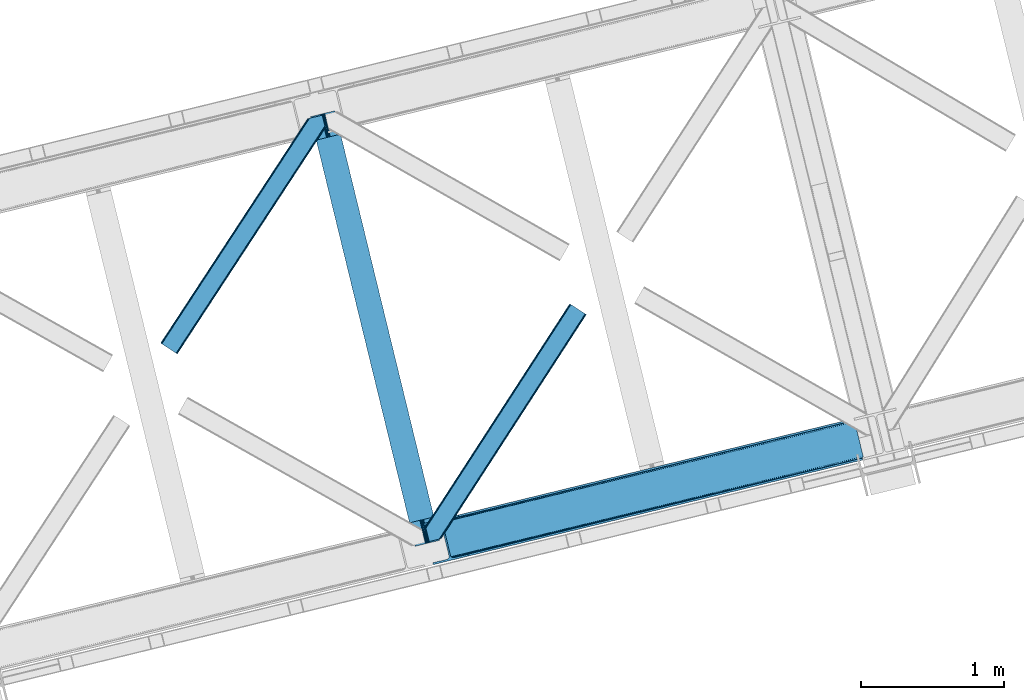
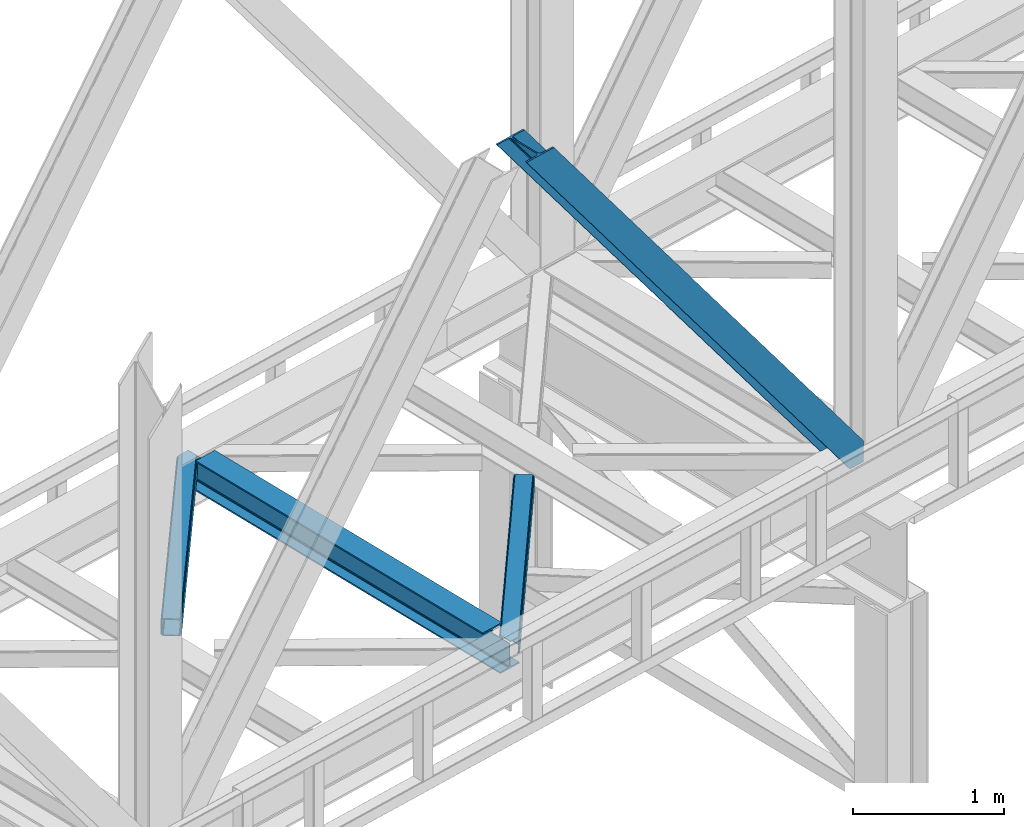
# One storey, part 53 of 93: 3 members, 1 beam.
"""IFC4 building model written with IfcOpenShell, lengths in millimetres."""

from ifc_helpers import new_model, entity, si_unit, converted_unit, derived_unit, direction, frame, origin, place, context, subcontext, project, spatial, triangles, polygons, material, type_object, element, save


model = new_model("IFC4")

# Units and contexts
model_context = context("Model", 3, precision=0.01, world=origin(), true_north=direction((6.12303176911189e-17, 1.0)))
plan_context = context("Plan", 3, precision=0.01, world=origin(), true_north=direction((6.12303176911189e-17, 1.0)))
body_context = subcontext(model_context, "Body", "Model", "MODEL_VIEW")
ifc_project = project(units=[si_unit("LENGTHUNIT", "METRE", prefix="MILLI"), si_unit("AREAUNIT", "SQUARE_METRE"), si_unit("VOLUMEUNIT", "CUBIC_METRE"), converted_unit("PLANEANGLEUNIT", "DEGREE", entity("IfcRatioMeasure", 0.0174532925199433), si_unit("PLANEANGLEUNIT", "RADIAN"), dimensions=[0, 0, 0, 0, 0, 0, 0]), si_unit("MASSUNIT", "GRAM", prefix="KILO"), derived_unit("MASSDENSITYUNIT", [(si_unit("MASSUNIT", "GRAM", prefix="KILO"), 1), (si_unit("LENGTHUNIT", "METRE"), -3)]), derived_unit("MOMENTOFINERTIAUNIT", [(si_unit("LENGTHUNIT", "METRE"), 4)]), si_unit("TIMEUNIT", "SECOND"), si_unit("FREQUENCYUNIT", "HERTZ"), si_unit("THERMODYNAMICTEMPERATUREUNIT", "DEGREE_CELSIUS"), derived_unit("THERMALTRANSMITTANCEUNIT", [(si_unit("MASSUNIT", "GRAM", prefix="KILO"), 1), (si_unit("THERMODYNAMICTEMPERATUREUNIT", "KELVIN"), -1), (si_unit("TIMEUNIT", "SECOND"), -3)]), derived_unit("VOLUMETRICFLOWRATEUNIT", [(si_unit("LENGTHUNIT", "METRE"), 3), (si_unit("TIMEUNIT", "SECOND"), -1)]), derived_unit("MASSFLOWRATEUNIT", [(si_unit("MASSUNIT", "GRAM", prefix="KILO"), 1), (si_unit("TIMEUNIT", "SECOND"), -1)]), derived_unit("ROTATIONALFREQUENCYUNIT", [(si_unit("TIMEUNIT", "SECOND"), -1)]), si_unit("ELECTRICCURRENTUNIT", "AMPERE"), si_unit("ELECTRICVOLTAGEUNIT", "VOLT"), si_unit("POWERUNIT", "WATT"), si_unit("FORCEUNIT", "NEWTON", prefix="KILO"), si_unit("ILLUMINANCEUNIT", "LUX"), si_unit("LUMINOUSFLUXUNIT", "LUMEN"), si_unit("LUMINOUSINTENSITYUNIT", "CANDELA"), derived_unit("USERDEFINED", [(si_unit("MASSUNIT", "GRAM", prefix="KILO"), -1), (si_unit("LENGTHUNIT", "METRE"), -2), (si_unit("TIMEUNIT", "SECOND"), 3), (si_unit("LUMINOUSFLUXUNIT", "LUMEN"), 1)]), derived_unit("LINEARVELOCITYUNIT", [(si_unit("LENGTHUNIT", "METRE"), 1), (si_unit("TIMEUNIT", "SECOND"), -1)]), si_unit("PRESSUREUNIT", "PASCAL"), derived_unit("USERDEFINED", [(si_unit("LENGTHUNIT", "METRE"), -2), (si_unit("MASSUNIT", "GRAM", prefix="KILO"), 1), (si_unit("TIMEUNIT", "SECOND"), -2)]), derived_unit("LINEARFORCEUNIT", [(si_unit("MASSUNIT", "GRAM", prefix="KILO"), 1), (si_unit("LENGTHUNIT", "METRE"), 1), (si_unit("TIMEUNIT", "SECOND"), -2), (si_unit("LENGTHUNIT", "METRE"), -1)]), derived_unit("PLANARFORCEUNIT", [(si_unit("MASSUNIT", "GRAM", prefix="KILO"), 1), (si_unit("LENGTHUNIT", "METRE"), 1), (si_unit("TIMEUNIT", "SECOND"), -2), (si_unit("LENGTHUNIT", "METRE"), -2)])], contexts=[model_context, plan_context])

# Site, building, storey
site_placement = place(None, origin())
site = spatial("IfcSite", under=ifc_project, at=site_placement, CompositionType="ELEMENT")
building_placement = place(site_placement, origin())
building = spatial("IfcBuilding", under=site, at=building_placement, CompositionType="ELEMENT")
storey_placement = place(building_placement, frame((0.0, 0.0, 15900.0)))
storey = spatial("IfcBuildingStorey", under=building, at=storey_placement, CompositionType="ELEMENT", Elevation=15900.0)

# Beam
ifc_material = material(Name="Metal painted (White)")
beam_type = type_object("IfcBeamType", PredefinedType="BEAM")
beam_placement = place(storey_placement, frame((-33403.9832699759, 9644.13047468046, 3441.0)))
element("IfcBeam", 1, at=beam_placement, inside=storey, type_object=beam_type, material=ifc_material, ObjectType="Steel Beam", PredefinedType="BEAM", context=body_context, shape_type="Tessellation", body=[
    polygons([(900.98534618944, 41.4445662733092, 11.000000000004), (900.98534618944, 41.4445662733092, 2.16573425859679e-12), (170.021610174761, 3040.13999372697, 2.16573425859679e-12), (170.021610174761, 3040.13999372697, 11.000000000004), (834.919806235814, 25.3403919499667, 11.000000000004), (103.956070221144, 3024.03581940363, 11.000000000004), (828.971056214522, 23.8903211957407, 12.2179274798217), (98.0073201998513, 3022.5857486494, 12.2179274798217), (823.927949458409, 22.6610105689183, 15.6862915010235), (92.964213443734, 3021.35643802258, 15.6862915010235), (820.558253255237, 21.8396114687119, 20.8770650821657), (89.5945172405668, 3020.53503892237, 20.8770650821657), (819.374973305552, 21.5511744621206, 27.0000000000047), (88.4112372908723, 3020.24660191578, 27.0000000000047), (81.6103728838844, 3018.58881926485, 27.0000000000025), (81.6103728838801, 3018.58881926485, 203.000000000006), (88.4112372908723, 3020.24660191578, 203.000000000006), (0.0, 2998.69542745366, 2.16573425859679e-12), (0.0, 2998.69542745366, 10.9999999999997), (66.0655399536216, 3014.799601777, 11.000000000004), (72.014289974914, 3016.24967253123, 12.2179274798217), (77.0573967310226, 3017.47898315805, 15.6862915010192), (80.4270929342029, 3018.30038225826, 20.8770650821657), (819.374973305552, 21.5511744621206, 203.000000000006), (812.574108898559, 19.8933918111876, 203.000000000006), (812.574108898559, 19.8933918111876, 27.0000000000025), (811.390828948882, 19.6049548045984, 20.8770650821657), (808.021132745702, 18.7835557043887, 15.6862915010192), (802.978025989593, 17.5542450775685, 12.2179274798217), (797.029275968301, 16.1041743233436, 11.000000000004), (730.963736014679, 0.0, 10.9999999999997), (730.963736014679, 0.0, 2.16573425859679e-12), (779.675212882766, 184.415062601693, 203.069791966819), (128.020401343512, 2857.75452019162, 203.000000000006), (128.243282132663, 2856.8401777572, 203.617301946336), (128.256196377186, 2856.7871977843, 217.000003693143), (779.530009633837, 185.010597404073, 217.000003676718), (779.530880241731, 185.007025963196, 204.00000679514), (772.96491171832, 182.385463974442, 203.006342981529), (772.742064056782, 183.299815969777, 203.617301946336), (772.729149812254, 183.352795942668, 217.000003693143), (121.455336555608, 2855.1293963229, 217.000003676718), (121.454465947714, 2855.13296776377, 204.00000679514), (121.31016635866, 2855.72494066435, 203.076120467494), (121.219536936524, 2856.09673754069, 203.000000000006), (780.713494357868, 185.298194377515, 223.122939328039), (784.082490766539, 186.122464201392, 228.313710402595), (789.125126170563, 187.353708426698, 231.782072735464), (795.073705041271, 188.804481281382, 232.999999602236), (861.139155906794, 204.909021065316, 232.999999283132), (861.137682570357, 204.915065042189, 243.999994005812), (691.11630166644, 163.469558245299, 243.999994827032), (691.117775002877, 163.463514268425, 233.000000104353), (757.183225868401, 179.568054052362, 232.999999785253), (763.132130996726, 181.017488520583, 231.782072861016), (768.175695503862, 182.244921343717, 228.313710479427), (771.546082413602, 183.063487001149, 223.12293937232), (120.271851831576, 2854.84179934946, 223.122939328039), (116.902855422897, 2854.01752952558, 228.313710402595), (111.860220018877, 2852.78628530027, 231.782072735464), (105.911641148165, 2851.33551244559, 232.999999602236), (39.8461902826505, 2835.23097266165, 232.999999283128), (39.8476636190881, 2835.22492868478, 243.999994005812), (209.869044523005, 2876.67043548167, 243.999994827032), (209.867571186567, 2876.67647945855, 233.000000104357), (143.80212032104, 2860.57193967461, 232.999999785253), (137.85321519271, 2859.12250520639, 231.782072861012), (132.809650685579, 2857.89507238325, 228.313710479427), (129.439263775838, 2857.07650672582, 223.12293937232)], [[[1, 2, 3, 4]], [[5, 1, 4, 6]], [[7, 5, 6, 8]], [[9, 7, 8, 10]], [[11, 9, 10, 12]], [[13, 11, 12, 14]], [[15, 16, 17, 14, 12, 10, 8, 6, 4, 3, 18, 19, 20, 21, 22, 23]], [[13, 24, 25, 26, 27, 28, 29, 30, 31, 32, 2, 1, 5, 7, 9, 11]], [[2, 32, 18, 3]], [[32, 31, 19, 18]], [[31, 30, 20, 19]], [[27, 26, 15, 23]], [[28, 27, 23, 22]], [[29, 28, 22, 21]], [[30, 29, 21, 20]], [[33, 24, 13, 14, 17, 34, 35, 36, 37, 38]], [[25, 39, 40, 41, 42, 43, 44, 16, 15, 26]], [[39, 25, 24, 33]], [[45, 34, 17, 16]], [[41, 40, 38, 37, 46, 47, 48, 49, 50, 51, 52, 53, 54, 55, 56, 57]], [[42, 58, 59, 60, 61, 62, 63, 64, 65, 66, 67, 68, 69, 36, 35, 43]], [[46, 37, 36, 69]], [[47, 46, 69, 68]], [[48, 47, 68, 67]], [[49, 48, 67, 66]], [[50, 49, 66, 65]], [[51, 50, 65, 64]], [[52, 51, 64, 63]], [[53, 52, 63, 62]], [[54, 53, 62, 61]], [[55, 54, 61, 60]], [[56, 55, 60, 59]], [[57, 56, 59, 58]], [[41, 57, 58, 42]]], closed=False),
])

# Members
member_type_1 = type_object("IfcMemberType", PredefinedType="BRACE")
member_1_placement = place(storey_placement, frame((-32615.8952087402, 9516.31855316162, 3694.99929199219)))
element("IfcMember", 2, at=member_1_placement, inside=storey, type_object=member_type_1, ObjectType="Steel Vertical Brace", PredefinedType="BRACE", context=body_context, shape_type="Tessellation", body=[
    triangles([(3070.87069702148, 756.345112609863, 0.827856445310317), (3071.52647094726, 755.357963562012, 1.13481445312209), (3070.10562744141, 754.873109436036, 0.0), (3068.17783813476, 762.778440856933, 0.0), (3067.78251342773, 753.546446228027, 7.26932373046657), (3067.78251342773, 753.546446228027, 0.0), (3064.92454833984, 750.387336730957, 0.0), (3063.48277587891, 746.379441833496, 0.0), (3065.2245300293, 750.173396301268, 14.9735046386704), (3064.09204101563, 748.68162689209, 18.377947998044), (3063.67113647461, 742.123887634278, 0.0), (3063.35952758789, 744.487696838378, 30.2981506347642), (3063.478125, 743.106385803223, 41.9881347656228), (3063.68508911133, 746.345722961425, 25.0194030761704), (3063.478125, 743.106385803223, 170.743066406249), (3063.67113647461, 742.123887634278, 170.803527832031), (215.791479492189, 48.9522445678704, 3911.00081176758), (310.560113525389, 72.0531600952145, 3911.00081176758), (192.892877197264, 54.8071197509762, 3911.00081176758), (199.032037353514, 50.2928604125973, 3911.00081176758), (207.07108154297, 48.2371719360344, 3911.00081176758), (189.588427734376, 61.0922012329102, 3911.00081176758), (3066.51282348633, 730.465296936034, 170.803527832031), (313.638995361329, 59.4225357055657, 3911.00081176758), (3066.51282348633, 730.465296936034, 0.0), (2948.45258789062, 701.686820983887, 0.0), (69.8631774902351, 0.0, 3911.00081176758), (2945.37370605469, 714.317445373536, 0.0), (66.7842956542954, 12.6300430297852, 3911.00081176758), (161.552929687499, 35.7309585571293, 3911.00081176758), (3040.14001464844, 737.417198181152, 0.0), (3057.81800537109, 760.25301361084, 0.0), (3057.77847290039, 753.153446960448, 0.0), (179.230920410155, 58.5667739868168, 3911.00081176758), (179.191387939452, 51.4677886962891, 3911.00081176758), (3054.40658569336, 746.321305847168, 0.0), (175.819500732421, 44.6350662231434, 3911.00081176758), (3048.21394042969, 740.794898986816, 0.0), (169.624530029298, 39.1086593627933, 3911.00081176758), (3002.63765258789, 986.625242614746, 0.0), (124.050567626953, 284.939002990723, 3911.00081176758), (2976.43460083008, 998.764036560058, 0.0), (2985.15732421875, 999.480271911621, 0.0), (106.567913818359, 297.794032287597, 3911.00081176758), (97.8475158691399, 297.078959655761, 3911.00081176758), (2993.1963684082, 997.424583435059, 0.0), (114.609283447266, 295.738343811036, 3911.00081176758), (2999.33552856445, 992.909742736816, 0.0), (120.748443603516, 291.223503112793, 3911.00081176758), (3.07888183593604, 273.978044128418, 3911.00081176758), (2881.66829223633, 975.664283752441, 0.0), (2878.58941040039, 988.29490814209, 0.0), (0.0, 286.60750579834, 3911.00081176758), (3012.99748535156, 989.150669860839, 0.0), (134.40807495117, 287.463267517089, 3911.00081176758), (144.014465332031, 306.922544860839, 3911.00081176758), (243.775817871094, 346.030622863769, 3911.00081176758), (152.08606567383, 310.300245666504, 3911.00081176758), (137.821820068359, 301.396138000488, 3911.00081176758), (134.449932861327, 294.563996887207, 3911.00081176758), (246.85469970703, 333.39999847412, 3911.00081176758), (2996.64964599609, 1017.07222137451, 170.803527832031), (2996.64964599609, 1017.07222137451, 0.0), (2999.49133300781, 1005.41363067627, 170.803527832031), (2999.77271118164, 1004.45322418213, 170.743066406249), (2999.77271118164, 1004.45322418213, 41.9881347656228), (2999.49133300781, 1005.41363067627, 0.0), (3008.39776611328, 997.164134216308, 0.0), (3001.28192138672, 1001.54875030518, 0.0), (3004.40731201172, 998.654740905762, 0.0), (3011.07202148438, 997.056001281739, 0.0), (3000.30291137695, 1003.17190704346, 30.2981506347642), (3001.44702758789, 1001.67199859619, 25.0194030761704), (3002.88182373047, 999.78490447998, 18.377947998044), (3004.57474365235, 998.981465148925, 14.9735046386704), (3008.39776611328, 997.164134216308, 7.26932373046657), (3012.55565185547, 997.279243469238, 1.13481445312209), (3012.42775268555, 996.10140838623, 0.827856445310317)], [[1, 2, 3], [3, 4, 1], [5, 6, 3], [7, 6, 5], [8, 7, 9], [9, 10, 8], [11, 12, 13], [11, 8, 14], [14, 12, 11], [13, 15, 16], [16, 11, 13], [10, 14, 8], [5, 9, 7], [3, 2, 5], [17, 18, 15], [15, 13, 17], [1, 19, 5], [19, 20, 10], [10, 9, 19], [9, 5, 19], [13, 12, 21], [21, 17, 13], [14, 20, 12], [14, 10, 20], [20, 21, 12], [5, 2, 1], [1, 4, 19], [22, 19, 4], [16, 15, 18], [23, 16, 24], [18, 24, 16], [23, 25, 16], [11, 16, 25], [24, 26, 23], [24, 27, 26], [26, 25, 23], [28, 26, 27], [27, 29, 28], [29, 30, 28], [31, 28, 30], [32, 33, 34], [35, 34, 33], [33, 36, 35], [37, 35, 36], [36, 38, 37], [39, 37, 38], [38, 31, 39], [30, 39, 31], [40, 32, 34], [34, 41, 40], [42, 43, 44], [44, 45, 42], [43, 46, 47], [47, 44, 43], [46, 48, 49], [49, 47, 46], [48, 40, 41], [41, 49, 48], [45, 50, 51], [51, 42, 45], [52, 51, 50], [50, 53, 52], [4, 54, 22], [55, 22, 54], [41, 34, 55], [37, 39, 21], [30, 27, 24], [29, 27, 30], [39, 30, 17], [34, 35, 19], [35, 37, 20], [47, 56, 44], [53, 45, 57], [45, 44, 58], [53, 50, 45], [47, 49, 59], [49, 41, 60], [55, 34, 22], [17, 21, 39], [19, 35, 20], [21, 20, 37], [19, 22, 34], [24, 17, 30], [24, 18, 17], [58, 44, 56], [59, 49, 60], [55, 60, 41], [59, 56, 47], [58, 57, 45], [57, 58, 61], [57, 52, 53], [52, 57, 62], [63, 52, 62], [64, 62, 57], [65, 64, 61], [57, 61, 64], [61, 58, 65], [66, 65, 58], [64, 67, 63], [63, 62, 64], [32, 40, 54], [46, 43, 67], [42, 52, 63], [51, 52, 42], [43, 42, 63], [40, 48, 68], [48, 46, 69], [36, 11, 38], [26, 31, 25], [31, 38, 25], [26, 28, 31], [36, 33, 8], [33, 32, 6], [8, 11, 36], [54, 40, 68], [67, 69, 46], [63, 67, 43], [48, 69, 70], [70, 68, 48], [71, 54, 68], [32, 54, 4], [8, 33, 7], [33, 6, 7], [11, 25, 38], [32, 4, 6], [3, 6, 4], [67, 72, 73], [65, 66, 64], [67, 64, 66], [66, 72, 67], [69, 74, 75], [69, 73, 74], [70, 75, 76], [76, 77, 71], [71, 68, 76], [76, 68, 70], [75, 70, 69], [73, 69, 67], [60, 78, 76], [76, 59, 60], [76, 75, 59], [74, 59, 75], [78, 77, 76], [54, 78, 60], [60, 55, 54], [73, 59, 74], [59, 73, 72], [56, 59, 72], [72, 66, 56], [58, 56, 66], [77, 78, 71], [54, 71, 78]]),
])
member_type_2 = type_object("IfcMemberType", PredefinedType="BRACE")
member_2_placement = place(storey_placement, frame((-34450.7785583496, 10986.0770965576, 3511.0000579834)))
element("IfcMember", 3, at=member_2_placement, inside=storey, type_object=member_type_2, ObjectType="Steel Horizontal Brace", PredefinedType="BRACE", context=body_context, shape_type="Tessellation", body=[
    triangles([(994.774163818358, 1564.02778930664, 0.0), (1028.82324829101, 1424.34794311523, 0.0), (14.6409667968692, 67.1040435791019, 0.0), (102.486767578121, 9.58662414550781, 0.0), (1.11388549804542, 75.9604797363281, 10.8028289794929), (0.0, 76.6906677246097, 17.5000946044929), (1025.02813110351, 1642.17999572754, 17.5000946044929), (4.28811035156104, 73.8826995849613, 5.12526855468968), (990.476751708979, 1585.8776184082, 9.50058288574292), (990.04654541015, 1584.44747314453, 8.74132690429906), (989.907019042963, 1583.99284973144, 8.50064392089917), (990.762780761717, 1580.48841247559, 5.12526855468968), (1027.30938720703, 1642.73577575684, 10.8702667236357), (1027.78145141601, 1642.85088500977, 9.50058288574292), (992.602203369141, 1572.93654785156, 1.33247680664135), (9.03898315429251, 70.7724243164066, 1.33247680664135), (1025.02813110351, 1642.17999572754, 122.500662231447), (0.0, 76.6906677246097, 122.500662231447), (1026.92103881836, 1642.64159545898, 129.197927856447), (1.11388549804542, 75.9604797363281, 129.197927856447), (1032.31605834961, 1643.95663146973, 134.874325561526), (4.28811035156104, 73.8826995849613, 134.874325561526), (1040.39463500976, 1645.9251159668, 138.667117309571), (9.03898315429251, 70.7724243164066, 138.667117309571), (1049.91963500976, 1648.24706726074, 139.999594116212), (14.6409667968692, 67.1040435791019, 139.999594116212), (994.871832275385, 1567.8519744873, 9.50058288574292), (994.762536621092, 1567.00783996582, 9.29478149414354), (994.648590087891, 1566.15091552734, 9.08781738281323), (994.541619873045, 1565.30678100586, 8.8831787109375), (994.746258544918, 1564.14522399902, 8.50064392089917), (1047.05469360351, 1647.54827270508, 9.50058288574292), (14.8944396972656, 66.9377746582031, 8.3320495605476), (20.4987487792969, 63.2705566406257, 6.99957275390625), (997.043792724609, 1554.7155670166, 6.99957275390625), (10.1458923339815, 70.0480499267578, 12.1260040283232), (1042.27359008789, 1646.38322753906, 12.1260040283232), (1036.87857055664, 1645.06819152832, 17.8035644531265), (1034.98333740234, 1644.60659179688, 24.4996673583992), (6.96934204101126, 72.1258300781246, 17.8035644531265), (5.85545654296584, 72.8560180664063, 24.4996673583992), (1026.55361938477, 1433.66016540527, 6.99957275390625), (96.6289855957002, 13.4212738037113, 6.99957275390625), (1028.71860351562, 1424.77698669434, 8.41343994140698), (1032.83463134765, 1407.88615722656, 5.12526855468968), (1033.6903930664, 1404.38288269043, 8.50064392089917), (1030.99520874023, 1415.43918457031, 1.33247680664135), (1034.98333740234, 1644.60659179688, 115.501089477541), (5.85545654296584, 72.8560180664063, 115.501089477541), (1050.34751586914, 1648.35171203613, 131.667544555665), (1059.87251586914, 1650.67366333008, 133.000021362306), (20.4987487792969, 63.2705566406257, 133.000021362306), (14.8944396972656, 66.9377746582031, 131.667544555665), (1042.27359008789, 1646.38322753906, 127.87475280762), (10.1458923339815, 70.0480499267578, 127.87475280762), (1036.87857055664, 1645.06819152832, 122.196029663086), (6.96934204101126, 72.1258300781246, 122.196029663086), (1128.10788574218, 1667.30636901856, 139.999594116212), (1128.10788574218, 1667.30636901856, 133.000021362306), (1144.33015136718, 1600.75810546875, 139.999594116212), (102.486767578121, 9.58662414550781, 139.999594116212), (1142.06052246093, 1610.07032775879, 133.000021362306), (96.6289855957002, 13.4212738037113, 133.000021362306), (1146.5021118164, 1591.84934692383, 138.667117309571), (108.088751220697, 5.91824340820313, 138.667117309571), (1148.34385986328, 1584.2974822998, 134.874325561526), (112.839624023436, 2.80796813964844, 134.874325561526), (1149.57401733398, 1579.2501159668, 129.197927856447), (116.011523437497, 0.730187988281614, 129.197927856447), (1150.00422363281, 1577.47813110351, 122.500662231447), (117.125408935543, 0.0, 122.500662231447), (1150.00422363281, 1577.47813110351, 17.5000946044929), (117.125408935543, 0.0, 17.5000946044929), (106.981842041016, 6.64261779785193, 127.87475280762), (110.156066894531, 4.5648376464851, 122.196029663086), (111.269952392577, 3.83464965820349, 115.501089477541), (102.233294677731, 9.75289306640661, 131.667544555665), (116.011523437497, 0.730187988281614, 10.8028289794929), (106.981842041016, 6.64261779785193, 12.1260040283232), (112.839624023436, 2.80796813964844, 5.12526855468968), (111.269952392577, 3.83464965820349, 24.4996673583992), (110.156066894531, 4.5648376464851, 17.8035644531265), (108.088751220697, 5.91824340820313, 1.33247680664135), (102.233294677731, 9.75289306640661, 8.3320495605476), (1147.30206298828, 1588.56233825684, 122.196029663086), (1147.73459472656, 1586.79035339356, 115.501089477541), (1146.07190551757, 1593.60854187012, 127.87475280762), (1144.23248291016, 1601.16156921387, 131.667544555665), (1147.73459472656, 1586.79035339356, 24.4996673583992), (1147.21369628906, 1588.92510681152, 17.869839477542), (1149.994921875, 1577.51650085449, 16.5001556396492), (1147.10672607421, 1589.36577758789, 16.5001556396492), (1145.27660522461, 1573.10863037109, 10.8714294433594), (1034.62056884765, 1404.788671875, 9.50058288574292), (1144.12783813477, 1572.03544006348, 9.50058288574292), (1142.79303588867, 1588.59838256836, 12.1260040283232), (1030.22548828125, 1422.8143157959, 9.50058288574292), (1029.19764404296, 1423.6724029541, 8.80643920898729), (1139.73275756836, 1590.06108398438, 9.50058288574292)], [[1, 2, 3], [4, 3, 2], [5, 6, 7], [8, 9, 10], [11, 12, 8], [5, 13, 9], [9, 8, 5], [13, 14, 9], [15, 1, 16], [3, 16, 1], [12, 15, 8], [16, 8, 15], [7, 13, 5], [17, 7, 6], [6, 18, 17], [19, 17, 20], [18, 20, 17], [21, 19, 22], [20, 22, 19], [23, 21, 24], [22, 24, 21], [25, 23, 26], [24, 26, 23], [27, 28, 9], [28, 29, 10], [29, 30, 10], [30, 31, 11], [14, 32, 27], [27, 9, 14], [33, 34, 35], [36, 33, 31], [31, 30, 36], [28, 36, 29], [28, 27, 36], [36, 30, 29], [32, 37, 27], [36, 27, 37], [35, 31, 33], [38, 39, 40], [41, 40, 39], [37, 38, 36], [40, 36, 38], [42, 35, 34], [34, 43, 42], [1, 35, 42], [31, 12, 11], [1, 31, 35], [31, 15, 12], [31, 1, 15], [2, 1, 42], [44, 2, 42], [45, 44, 46], [44, 47, 2], [44, 45, 47], [39, 48, 41], [49, 41, 48], [50, 51, 52], [52, 53, 50], [54, 50, 53], [53, 55, 54], [56, 54, 55], [55, 57, 56], [48, 56, 57], [57, 49, 48], [56, 17, 19], [50, 23, 25], [58, 51, 25], [51, 58, 59], [51, 50, 25], [54, 23, 50], [54, 56, 21], [21, 23, 54], [19, 21, 56], [39, 7, 17], [37, 14, 38], [56, 48, 17], [37, 32, 14], [39, 38, 7], [48, 39, 17], [13, 7, 38], [38, 14, 13], [60, 25, 61], [25, 60, 58], [26, 61, 25], [51, 62, 63], [51, 59, 62], [63, 52, 51], [64, 60, 61], [61, 65, 64], [66, 64, 65], [65, 67, 66], [68, 66, 67], [67, 69, 68], [70, 68, 69], [69, 71, 70], [72, 70, 71], [71, 73, 72], [69, 74, 75], [76, 73, 71], [69, 75, 71], [69, 67, 74], [75, 76, 71], [74, 67, 65], [63, 61, 26], [61, 77, 65], [77, 61, 63], [77, 74, 65], [78, 79, 80], [81, 73, 76], [73, 82, 78], [82, 73, 81], [78, 82, 79], [4, 43, 3], [83, 80, 79], [79, 84, 83], [84, 43, 4], [4, 83, 84], [55, 24, 22], [26, 52, 63], [26, 53, 52], [53, 26, 24], [55, 53, 24], [49, 18, 6], [20, 57, 55], [22, 20, 55], [57, 20, 18], [49, 57, 18], [16, 36, 8], [3, 43, 34], [34, 33, 3], [33, 36, 16], [16, 3, 33], [5, 8, 36], [6, 41, 49], [40, 6, 5], [6, 40, 41], [40, 5, 36], [85, 86, 75], [76, 75, 86], [87, 85, 74], [75, 74, 85], [88, 87, 77], [74, 77, 87], [62, 88, 63], [77, 63, 88], [86, 89, 81], [81, 76, 86], [90, 91, 92], [70, 72, 89], [72, 90, 89], [89, 86, 70], [72, 91, 90], [85, 70, 86], [68, 70, 85], [66, 85, 87], [85, 66, 68], [87, 64, 66], [88, 64, 87], [88, 62, 60], [88, 60, 64], [62, 58, 60], [62, 59, 58], [73, 78, 93], [93, 72, 73], [94, 93, 78], [94, 95, 93], [80, 45, 46], [46, 78, 80], [46, 94, 78], [47, 45, 83], [80, 83, 45], [2, 47, 4], [83, 4, 47], [93, 91, 72], [82, 81, 89], [82, 92, 96], [82, 90, 92], [84, 97, 98], [79, 96, 97], [97, 84, 79], [96, 99, 97], [43, 84, 44], [44, 42, 43], [96, 79, 82], [89, 90, 82], [96, 91, 93], [96, 92, 91], [96, 95, 99], [93, 95, 96], [99, 95, 97], [94, 97, 95]]),
])
member_type_3 = type_object("IfcMemberType", PredefinedType="BRACE")
member_3_placement = place(storey_placement, frame((-32601.7216552734, 9677.14885253906, 3510.05825500488)))
element("IfcMember", 4, at=member_3_placement, inside=storey, type_object=member_type_3, ObjectType="Steel Horizontal Brace", PredefinedType="BRACE", context=body_context, shape_type="Tessellation", body=[
    triangles([(1021.07255859375, 1650.67133789062, 0.387185668947495), (1109.18811035156, 1593.56668395996, 0.387185668947495), (114.153497314452, 251.255593872071, 0.0209289550803078), (148.353735351564, 110.958343505859, 0.0), (1007.50594482422, 1659.46266174316, 11.1900146484404), (0.523223876953125, 105.142419433594, 10.85166320801), (0.0, 107.29112548828, 17.4814910888672), (108.346874999999, 270.855560302734, 9.46221313476781), (0.634844970703853, 104.692446899413, 9.46221313476781), (1010.68947143555, 1657.39999694824, 5.51245422363354), (110.123510742189, 267.789468383789, 5.14968566894822), (109.277050781249, 271.259024047851, 8.46227416992406), (108.646856689455, 271.243908691406, 9.38547363281396), (1015.454296875, 1654.31297607422, 1.71849975586156), (111.972235107423, 260.203884887695, 1.35456848144531), (1006.38740844727, 1660.18587341309, 17.8872802734404), (1006.37345581055, 1660.16610717773, 122.886685180667), (0.0, 107.29112548828, 122.482058715821), (1021.05860595703, 1650.64575805664, 140.385617065433), (1015.43801879883, 1654.28855895996, 139.055465698242), (3.51838989257885, 92.8559600830067, 138.646188354494), (5.69965209961083, 83.9088317871083, 139.976339721681), (1010.67319335938, 1657.37674255371, 135.260348510743), (1.66966552734448, 100.442706298827, 134.853396606446), (1007.4919921875, 1659.44057006836, 129.583950805667), (0.434857177733647, 105.511001586914, 129.17699890137), (112.781488037108, 252.660159301757, 9.46221313476781), (5.05317993164135, 86.5644836425781, 9.46221313476781), (1021.32603149414, 1650.50506896973, 8.7192352294951), (113.111700439455, 252.928747558593, 9.38547363281396), (113.818634033203, 251.768353271484, 8.76806945800854), (1016.56353149414, 1653.59208984375, 12.5120269775398), (3.95092163085792, 91.089788818359, 12.1039123535156), (1026.9489440918, 1646.86343078613, 7.38675842285375), (114.255816650391, 250.833526611328, 8.40646362304688), (116.434753417969, 241.902676391601, 7.01933898925927), (1013.38000488281, 1655.65475463867, 18.1895874023467), (2.71378784179615, 96.1580841064442, 17.7826354980498), (1012.25914306641, 1656.37680358887, 24.8868530273467), (2.28125610351708, 97.9382080078121, 24.4799011230498), (1103.31172485352, 1597.372265625, 7.38675842285375), (146.072479248047, 120.311260986327, 7.00073547363354), (150.534997558592, 102.010052490234, 1.33015136719041), (148.353735351564, 110.953692626952, 8.46227416992406), (152.383721923827, 94.4244689941406, 5.1229431152351), (153.234832763672, 90.9316589355458, 8.46227416992406), (1012.24984130859, 1656.36052551269, 115.887112426761), (2.28125610351708, 97.9382080078121, 115.480160522464), (1013.36837768555, 1655.63498840332, 122.584378051761), (2.71378784179615, 96.1580841064442, 122.177426147464), (1016.54957885742, 1653.57116088867, 128.260775756837), (3.95092163085792, 91.089788818359, 127.85382385254), (1021.31207885742, 1650.48297729492, 132.053567504885), (5.79964599609229, 83.5030426025387, 131.644290161134), (1026.93266601563, 1646.8401763916, 133.386044311526), (7.98090820312427, 74.554751586913, 132.976766967775), (26.1542175292961, 0.0, 139.964712524416), (26.1542175292961, 0.0, 132.965139770509), (1109.17183227539, 1593.54110412598, 140.385617065433), (85.8808044433608, 14.5589950561516, 139.974014282227), (1103.30009765625, 1597.3501739502, 133.386044311526), (75.9744323730483, 12.1440261840817, 132.972116088869), (1123.85930786133, 1584.02656860351, 122.886685180667), (1122.74077148438, 1584.75094299316, 129.583950805667), (110.646734619142, 20.5958358764638, 122.477407836916), (108.760803222656, 20.1359802246097, 129.174673461916), (1119.55724487305, 1586.81244506836, 135.260348510743), (103.391363525392, 18.8279205322269, 134.851071166995), (1114.79241943359, 1589.89946594238, 139.055465698242), (95.3569702148452, 16.8693191528309, 138.64386291504), (1123.87093505859, 1584.04633483887, 17.8872802734404), (110.646734619142, 20.5958358764638, 17.478002929689), (1122.75472412109, 1584.77187194824, 11.1900146484404), (1113.69713745117, 1590.64244384766, 12.5120269775398), (1116.8806640625, 1588.57861633301, 18.1895874023467), (1117.996875, 1587.85191650391, 24.8868530273467), (1119.57119750977, 1586.83686218262, 5.51245422363354), (1114.80869750976, 1589.92504577637, 1.71849975586156), (1108.93231201172, 1593.73062744141, 8.7192352294951), (1113.68318481445, 1590.62035217285, 128.260775756837), (1117.98524780274, 1587.83563842773, 115.887112426761), (1116.86903686524, 1588.55885009766, 122.584378051761), (1108.918359375, 1593.70737304687, 132.053567504885), (85.4505981445327, 14.454350280761, 131.641964721683), (93.4849914550796, 16.4129516601552, 127.849172973634), (98.8521057128892, 17.721011352538, 122.172775268555), (100.74036254883, 18.1808670043938, 115.477835083009), (100.74036254883, 18.1808670043938, 24.4764129638679), (93.4849914550796, 16.4129516601552, 12.1015869140647), (107.895739746094, 19.9255279541012, 9.46221313476781), (98.8521057128892, 17.721011352538, 17.7791473388679), (88.6992370605476, 15.2461624145508, 9.46221313476781), (108.372454833985, 20.0412185668938, 10.8481750488281), (152.669750976562, 89.0306121826161, 9.46221313476781), (153.097631835939, 90.4723846435536, 8.7041198730476), (148.239788818359, 107.195782470702, 9.46221313476781), (148.563024902345, 109.771206665038, 8.84480895996239), (148.458380126955, 108.917770385742, 9.04944763183812), (148.349084472655, 108.050381469726, 9.25757446289208)], [[1, 2, 3], [4, 3, 2], [5, 6, 7], [8, 6, 5], [8, 9, 6], [10, 11, 12], [12, 5, 10], [12, 13, 5], [10, 14, 11], [15, 11, 14], [14, 1, 15], [3, 15, 1], [7, 16, 5], [17, 16, 18], [7, 18, 16], [19, 20, 21], [21, 22, 19], [20, 23, 24], [24, 21, 20], [23, 25, 26], [26, 24, 23], [25, 17, 18], [18, 26, 25], [8, 27, 9], [28, 9, 27], [29, 30, 31], [32, 33, 27], [27, 29, 32], [33, 28, 27], [34, 29, 35], [35, 36, 34], [32, 37, 38], [38, 33, 32], [37, 39, 40], [40, 38, 37], [41, 34, 36], [36, 42, 41], [36, 3, 42], [15, 35, 11], [35, 15, 3], [11, 35, 12], [3, 36, 35], [42, 3, 4], [43, 44, 4], [44, 43, 45], [4, 44, 42], [45, 46, 44], [39, 47, 48], [48, 40, 39], [47, 49, 48], [50, 48, 49], [49, 51, 50], [52, 50, 51], [51, 53, 52], [54, 52, 53], [53, 55, 54], [56, 54, 55], [52, 24, 50], [54, 56, 22], [56, 57, 22], [56, 58, 57], [21, 54, 22], [52, 21, 24], [33, 9, 28], [52, 54, 21], [7, 40, 48], [48, 50, 18], [18, 7, 48], [24, 26, 50], [50, 26, 18], [7, 38, 40], [38, 9, 33], [9, 38, 6], [7, 6, 38], [59, 22, 60], [59, 19, 22], [22, 57, 60], [61, 56, 55], [56, 61, 62], [58, 56, 62], [63, 64, 65], [66, 65, 64], [64, 67, 66], [68, 66, 67], [67, 69, 68], [70, 68, 69], [69, 59, 70], [60, 70, 59], [71, 63, 65], [65, 72, 71], [73, 74, 75], [76, 63, 71], [73, 75, 71], [73, 77, 74], [75, 76, 71], [74, 77, 78], [41, 2, 1], [2, 79, 78], [79, 2, 41], [79, 74, 78], [64, 80, 67], [81, 63, 76], [63, 82, 64], [82, 63, 81], [64, 82, 80], [59, 61, 19], [69, 67, 80], [80, 83, 69], [83, 61, 59], [59, 69, 83], [32, 14, 10], [1, 34, 41], [1, 29, 34], [29, 1, 14], [32, 29, 14], [39, 16, 17], [5, 37, 32], [10, 5, 32], [37, 5, 16], [39, 37, 16], [20, 51, 23], [19, 61, 55], [55, 53, 19], [53, 51, 20], [20, 19, 53], [25, 23, 51], [17, 47, 39], [49, 17, 25], [17, 49, 47], [49, 25, 51], [61, 83, 84], [84, 62, 61], [83, 80, 85], [85, 84, 83], [80, 82, 86], [86, 85, 80], [82, 81, 87], [87, 86, 82], [81, 76, 87], [88, 87, 76], [86, 65, 66], [84, 70, 60], [62, 57, 58], [60, 62, 84], [62, 60, 57], [85, 70, 84], [85, 86, 68], [68, 70, 85], [66, 68, 86], [72, 65, 87], [89, 90, 91], [86, 87, 65], [89, 92, 90], [88, 91, 72], [88, 72, 87], [93, 72, 91], [91, 90, 93], [73, 71, 72], [77, 94, 95], [46, 45, 77], [73, 93, 94], [94, 77, 73], [93, 90, 94], [2, 78, 4], [43, 4, 78], [78, 77, 43], [45, 43, 77], [72, 93, 73], [79, 41, 42], [89, 74, 96], [74, 79, 44], [44, 97, 74], [74, 98, 99], [98, 74, 97], [99, 96, 74], [96, 92, 89], [42, 44, 79], [76, 75, 88], [91, 88, 75], [75, 74, 91], [89, 91, 74], [96, 99, 94], [99, 98, 95], [98, 97, 95], [97, 44, 46], [96, 94, 90], [90, 92, 96]]),
])

save(model, "model.ifc")
